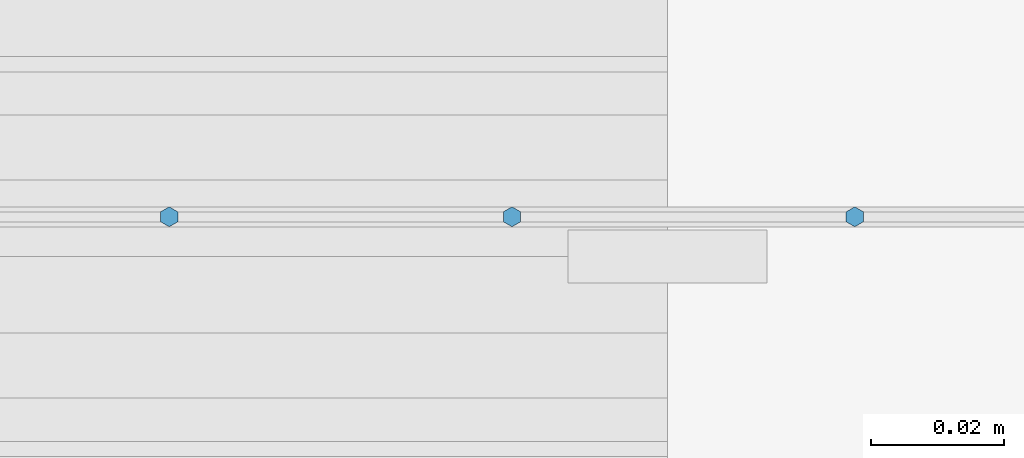
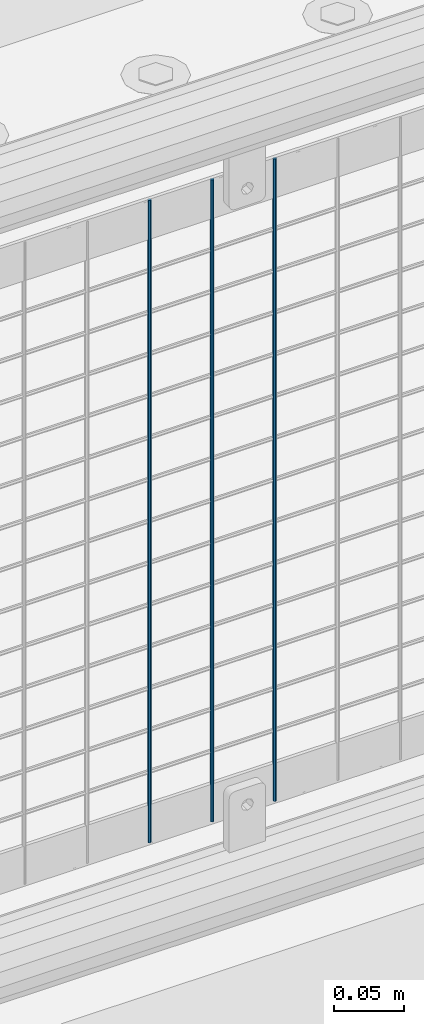
# One storey, part 66 of 193: 3 columns.
"""IFC2X3 building model written with IfcOpenShell, lengths in millimetres."""

from ifc_helpers import new_model, si_unit, frame, origin_with_axes, place, context, subcontext, project, spatial, faceted_brep, material, type_object, element, save


model = new_model("IFC2X3")

# Units and contexts
model_context = context("Model", 3, precision=1e-05, world=origin_with_axes())
body_context = subcontext(model_context, "Body", "Model", "MODEL_VIEW")
ifc_project = project(units=[si_unit("LENGTHUNIT", "METRE", prefix="MILLI"), si_unit("AREAUNIT", "SQUARE_METRE"), si_unit("VOLUMEUNIT", "CUBIC_METRE"), si_unit("MASSUNIT", "GRAM", prefix="KILO"), si_unit("TIMEUNIT", "SECOND"), si_unit("PLANEANGLEUNIT", "RADIAN"), si_unit("SOLIDANGLEUNIT", "STERADIAN"), si_unit("THERMODYNAMICTEMPERATUREUNIT", "DEGREE_CELSIUS"), si_unit("LUMINOUSINTENSITYUNIT", "LUMEN")], contexts=[model_context])

# Site, building, storey
site_placement = place(None, origin_with_axes())
site = spatial("IfcSite", under=ifc_project, at=site_placement, CompositionType="ELEMENT")
building_placement = place(site_placement, origin_with_axes())
building = spatial("IfcBuilding", under=site, at=building_placement, Name="Standard", CompositionType="ELEMENT")
storey_placement = place(building_placement, origin_with_axes())
storey = spatial("IfcBuildingStorey", under=building, at=storey_placement, Name="Undefined", CompositionType="ELEMENT", Elevation=0.0)

# Columns
ifc_material = material(Name="Misc_Undefined")
column_type = type_object("IfcColumnType", Name="D3", PredefinedType="NOTDEFINED")
for number, where, z_axis, x_axis in (
    (1, (-36361.76, 28670.5, 353.02), (-1.0, 0.0, 0.0), (0.0, 0.0, 1.0)),
    (2, (-36413.415, 28670.5, 353.02), (-1.0, 0.0, 0.0), (0.0, 0.0, 1.0)),
    (3, (-36465.07, 28670.5, 353.02), (-1.0, 0.0, 0.0), (0.0, 0.0, 1.0)),
):
    element("IfcColumn", number, at=place(storey_placement, frame(where, z_axis=z_axis, x_axis=x_axis)), inside=storey, type_object=column_type, material=ifc_material, ObjectType="D3", context=body_context, shape_type="Brep", body=[
        faceted_brep([(0.0, -1.49999999999636, 3.63797880709171e-12), (0.0, -0.75, -1.29903810567669), (560.0, -0.75, -1.29903810567703), (560.0, -1.5, 0.0), (0.0, 0.75, -1.29903810567669), (560.0, 0.75, -1.29903810567703), (0.0, 1.50000000000364, 7.27595761418343e-12), (560.0, 1.5, 0.0), (0.0, 0.75, 1.29903810567669), (560.0, 0.75, 1.29903810567703), (0.0, -0.75, 1.29903810567669), (560.0, -0.75, 1.29903810567703)], [[[0, 1, 2, 3]], [[1, 4, 5, 2]], [[4, 6, 7, 5]], [[6, 8, 9, 7]], [[8, 10, 11, 9]], [[10, 0, 3, 11]], [[5, 7, 9, 11, 3, 2]], [[10, 8, 6, 4, 1, 0]]]),
    ])

save(model, "model.ifc")
